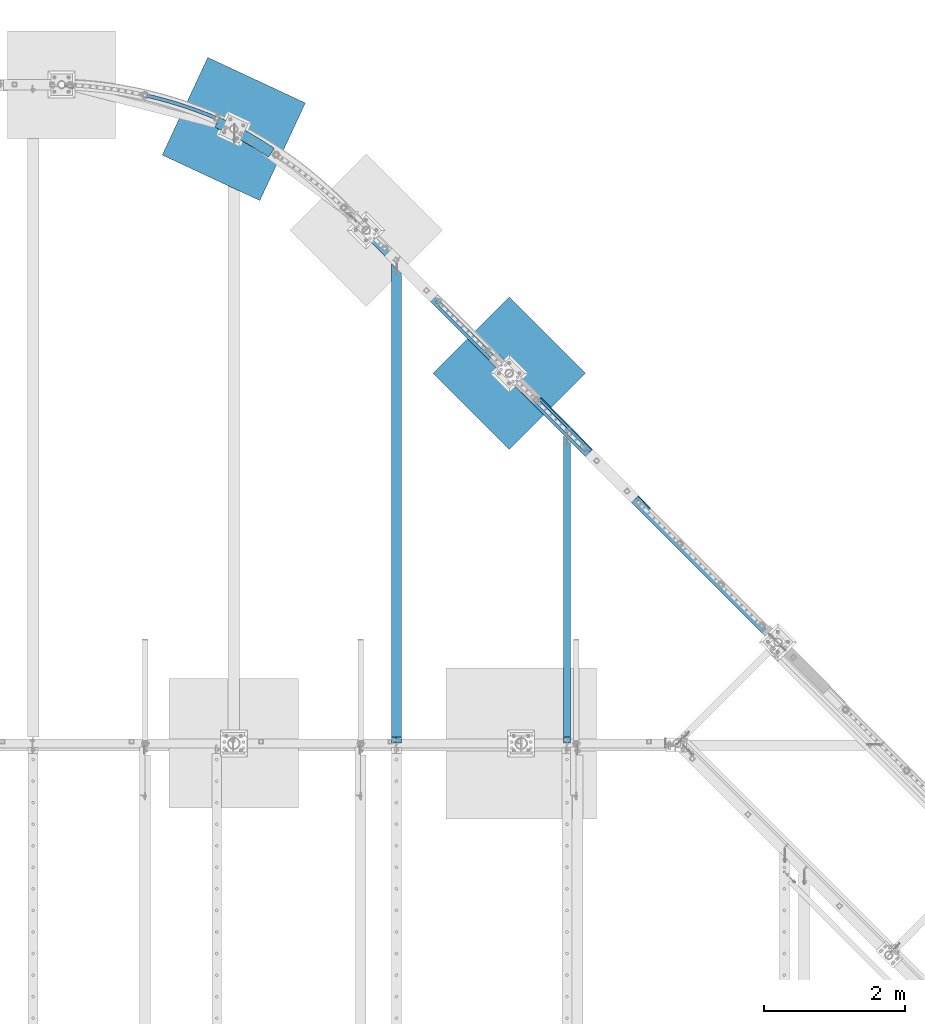
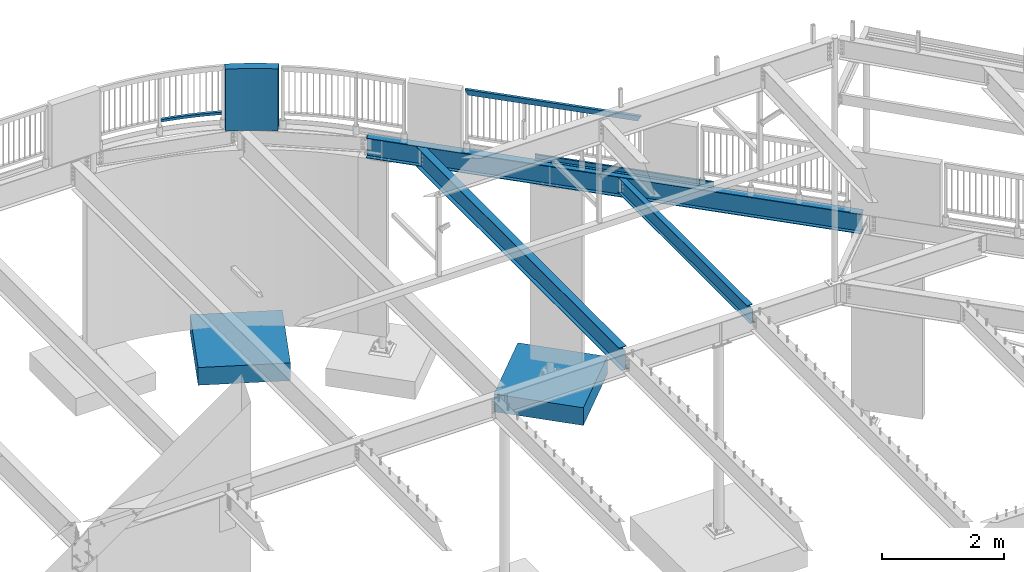
# One storey, part 331 of 975: 9 beams.
"""IFC2X3 building model written with IfcOpenShell, lengths in millimetres."""

from ifc_helpers import new_model, si_unit, frame, origin_with_axes, place, context, subcontext, project, spatial, faceted_brep, material, type_object, element, save


model = new_model("IFC2X3")

# Units and contexts
model_context = context("Model", 3, precision=1e-05, world=origin_with_axes())
body_context = subcontext(model_context, "Body", "Model", "MODEL_VIEW")
ifc_project = project(units=[si_unit("LENGTHUNIT", "METRE", prefix="MILLI"), si_unit("AREAUNIT", "SQUARE_METRE"), si_unit("VOLUMEUNIT", "CUBIC_METRE"), si_unit("MASSUNIT", "GRAM", prefix="KILO"), si_unit("TIMEUNIT", "SECOND"), si_unit("PLANEANGLEUNIT", "RADIAN"), si_unit("SOLIDANGLEUNIT", "STERADIAN"), si_unit("THERMODYNAMICTEMPERATUREUNIT", "DEGREE_CELSIUS"), si_unit("LUMINOUSINTENSITYUNIT", "LUMEN")], contexts=[model_context])

# Site, building, storey
site_placement = place(None, origin_with_axes())
site = spatial("IfcSite", under=ifc_project, at=site_placement, CompositionType="ELEMENT")
building_placement = place(site_placement, origin_with_axes())
building = spatial("IfcBuilding", under=site, at=building_placement, Name="Undefined", CompositionType="ELEMENT")
storey_placement = place(building_placement, origin_with_axes())
storey = spatial("IfcBuildingStorey", under=building, at=storey_placement, Name="Undefined", CompositionType="ELEMENT", Elevation=0.0)

# Beams
ifc_material_1 = material()
beam_type_1 = type_object("IfcBeamType", Name="HSS2X2X.188_TUBES", PredefinedType="NOTDEFINED")
beam_1_placement = place(storey_placement, frame((16519.5331439159, 29957.1361658595, 4229.10000192006), z_axis=(0.0, 0.0, 1.0), x_axis=(0.975010716016224, -0.222157835003697, 0.0)))
element("IfcBeam", 1, at=beam_1_placement, inside=storey, type_object=beam_type_1, material=ifc_material_1, Name="GUARDRAIL", ObjectType="HSS2X2X.188_TUBES", context=body_context, shape_type="Brep", body=[
    faceted_brep([(1150.31871985149, 124.980807145817, -25.3999999999996), (1150.31871985149, 124.980807145817, 25.3999999999996), (1187.76761016371, 124.51871128966, 25.3999999999996), (1187.76761016371, 124.51871128966, -25.3999999999996), (1225.21293697986, 123.82558949032, 25.3999999999996), (1225.21293697986, 123.82558949032, -25.3999999999996), (1262.6532750914, 122.90146812873, 25.3999999999996), (1262.6532750914, 122.90146812873, -25.3999999999996), (1300.08719947965, 121.746382377933, 25.3999999999996), (1300.08719947965, 121.746382377933, -25.3999999999996), (1337.51328537006, 120.360376201708, 25.3999999999996), (1337.51328537006, 120.360376201708, -25.3999999999996), (1374.93010828641, 118.743502352903, 25.3999999999996), (1374.93010828641, 118.743502352903, -25.3999999999996), (1412.33624410506, 116.895822371444, 25.3999999999996), (1412.33624410506, 116.895822371444, -25.3999999999996), (1449.73026910911, 114.817406581969, 25.3999999999996), (1449.73026910911, 114.817406581969, -25.3999999999996), (1487.11076004261, 112.508334091181, 25.3999999999996), (1487.11076004261, 112.508334091181, -25.3999999999996), (1524.47629416474, 109.968692784802, 25.3999999999996), (1524.47629416474, 109.968692784802, -25.3999999999996), (1561.82544930395, 107.198579324249, 25.3999999999996), (1561.82544930395, 107.198579324249, -25.3999999999996), (1599.15680391209, 104.198099142952, 25.3999999999996), (1599.15680391209, 104.198099142952, -25.3999999999996), (1636.46893711852, 100.967366442361, 25.3999999999996), (1636.46893711852, 100.967366442361, -25.3999999999996), (1673.76042878418, 97.5065041875496, 25.3999999999996), (1673.76042878418, 97.5065041875496, -25.3999999999996), (1711.02985955566, 93.8156441025785, 25.3999999999996), (1711.02985955566, 93.8156441025785, -25.3999999999996), (1748.2758109192, 89.8949266654745, 25.3999999999996), (1748.2758109192, 89.8949266654745, -25.3999999999996), (1785.4968652547, 85.744501102854, 25.3999999999996), (1785.4968652547, 85.744501102854, -25.3999999999996), (1822.69160588967, 81.3645253842988, 25.3999999999996), (1822.69160588967, 81.3645253842988, -25.3999999999996), (1859.85861715311, 76.7551662162805, 25.3999999999996), (1859.85861715311, 76.7551662162805, -25.3999999999996), (1896.99648442949, 71.9165990358742, 25.3999999999996), (1896.99648442949, 71.9165990358742, -25.3999999999996), (1934.10379421248, 66.8490080040283, 25.3999999999996), (1934.10379421248, 66.8490080040283, -25.3999999999996), (1971.17913415883, 61.5525859985864, 25.3999999999996), (1971.17913415883, 61.5525859985864, -25.3999999999996), (2008.22109314208, 56.0275346069466, 25.3999999999996), (2008.22109314208, 56.0275346069466, -25.3999999999996), (2045.2282613063, 50.2740641183846, 25.3999999999996), (2045.2282613063, 50.2740641183846, -25.3999999999996), (2082.19923011971, 44.2923935160434, 25.3999999999996), (2082.19923011971, 44.2923935160434, -25.3999999999996), (2119.13259242833, 38.0827504685949, 25.3999999999996), (2119.13259242833, 38.0827504685949, -25.3999999999996), (2132.13149665753, 35.8146830047481, 25.3999999999996), (2132.13149665753, 35.8146830047481, -25.3999999999996), (2110.55526379542, -11.9878939603732, 25.3999999999996), (2110.55526379542, -11.9878939603732, -25.3999999999996), (2123.09401412406, -14.1756731113128, -25.3999999999996), (2123.09401412406, -14.1756731113128, 25.3999999999996), (2073.93096728016, -5.83021445306804, 25.3999999999996), (2073.93096728016, -5.83021445306804, -25.3999999999996), (2037.26937895892, 0.101400328334421, 25.3999999999996), (2037.26937895892, 0.101400328334421, -25.3999999999996), (2000.57189421031, 5.80672462034272, 25.3999999999996), (2000.57189421031, 5.80672462034272, -25.3999999999996), (1963.83990977922, 11.2855412723002, 25.3999999999996), (1963.83990977922, 11.2855412723002, -25.3999999999996), (1927.07482372363, 16.5376417546795, 25.3999999999996), (1927.07482372363, 16.5376417546795, -25.3999999999996), (1890.27803536142, 21.5628261670136, 25.3999999999996), (1890.27803536142, 21.5628261670136, -25.3999999999996), (1853.45094521706, 26.3609032454988, 25.3999999999996), (1853.45094521706, 26.3609032454988, -25.3999999999996), (1816.59495496837, 30.9316903702711, 25.3999999999996), (1816.59495496837, 30.9316903702711, -25.3999999999996), (1779.71146739312, 35.2750135723545, 25.3999999999996), (1779.71146739312, 35.2750135723545, -25.3999999999996), (1742.80188631566, 39.390707540304, 25.3999999999996), (1742.80188631566, 39.390707540304, -25.3999999999996), (1705.86761655348, 43.2786156264701, 25.3999999999996), (1705.86761655348, 43.2786156264701, -25.3999999999996), (1668.91006386378, 46.9385898529872, 25.3999999999996), (1668.91006386378, 46.9385898529872, -25.3999999999996), (1631.93063488987, 50.370490917383, 25.3999999999996), (1631.93063488987, 50.370490917383, -25.3999999999996), (1594.93073710776, 53.5741881978829, 25.3999999999996), (1594.93073710776, 53.5741881978829, -25.3999999999996), (1557.91177877249, 56.5495597584159, 25.3999999999996), (1557.91177877249, 56.5495597584159, -25.3999999999996), (1520.87516886458, 59.2964923531908, 25.3999999999996), (1520.87516886458, 59.2964923531908, -25.3999999999996), (1483.82231703636, 61.8148814310625, 25.3999999999996), (1483.82231703636, 61.8148814310625, -25.3999999999996), (1446.75463355837, 64.1046311395039, 25.3999999999996), (1446.75463355837, 64.1046311395039, -25.3999999999996), (1409.67352926565, 66.1656543282297, 25.3999999999996), (1409.67352926565, 66.1656543282297, -25.3999999999996), (1372.58041550406, 67.9978725525216, 25.3999999999996), (1372.58041550406, 67.9978725525216, -25.3999999999996), (1335.47670407655, 69.601216076233, 25.3999999999996), (1335.47670407655, 69.601216076233, -25.3999999999996), (1298.3638071894, 70.9756238744158, 25.3999999999996), (1298.3638071894, 70.9756238744158, -25.3999999999996), (1261.24313739854, 72.1210436356632, 25.3999999999996), (1261.24313739854, 72.1210436356632, -25.3999999999996), (1224.11610755572, 73.0374317640963, 25.3999999999996), (1224.11610755572, 73.0374317640963, -25.3999999999996), (1186.98413075477, 73.7247533810223, 25.3999999999996), (1186.98413075477, 73.7247533810223, -25.3999999999996), (1149.84862027779, 74.1829823262451, 25.3999999999996), (1149.84862027779, 74.1829823262451, -25.3999999999996), (1114.28344501515, 74.4023999704295, 25.3999999999996), (1114.28344501515, 74.4023999704295, -25.3999999999996), (1114.13455093549, 125.204043641672, -25.3999999999996), (1114.13455093549, 125.204043641672, 25.3999999999996), (1150.27464801645, 120.218511068982, 20.6374999999998), (1150.27464801645, 120.218511068982, -20.6374999999998), (1187.69415896912, 119.756777735725, -20.6374999999998), (1187.69415896912, 119.756777735725, 20.6374999999998), (1225.11010922135, 119.064199703484, -20.6374999999998), (1225.11010922135, 119.064199703484, 20.6374999999998), (1262.52107468269, 118.140803332506, -20.6374999999998), (1262.52107468269, 118.140803332506, 20.6374999999998), (1299.92563145244, 116.986623768229, -20.6374999999998), (1299.92563145244, 116.986623768229, 20.6374999999998), (1337.32235587379, 115.601704939945, -20.6374999999998), (1337.32235587379, 115.601704939945, 20.6374999999998), (1374.70982458807, 113.986099559123, -20.6374999999998), (1374.70982458807, 113.986099559123, 20.6374999999998), (1412.08661458888, 112.139869117396, -20.6374999999998), (1412.08661458888, 112.139869117396, 20.6374999999998), (1449.45130327623, 110.063083884241, -20.6374999999998), (1449.45130327623, 110.063083884241, 20.6374999999998), (1486.80246851077, 107.755822904299, -20.6374999999998), (1486.80246851077, 107.755822904299, 20.6374999999998), (1524.13868866785, 105.218173994333, -20.6374999999998), (1524.13868866785, 105.218173994333, 20.6374999999998), (1561.45854269162, 102.450233739946, -20.6374999999998), (1561.45854269162, 102.450233739946, 20.6374999999998), (1598.76061014918, 99.4521074918521, -20.6374999999998), (1598.76061014918, 99.4521074918521, 20.6374999999998), (1636.04347128458, 96.2239093618919, -20.6374999999998), (1636.04347128458, 96.2239093618919, 20.6374999999998), (1673.30570707289, 92.7657622186816, -20.6374999999998), (1673.30570707289, 92.7657622186816, 20.6374999999998), (1710.54589927421, 89.0777976829486, -20.6374999999998), (1710.54589927421, 89.0777976829486, 20.6374999999998), (1747.76263048762, 85.1601561224888, -20.6374999999998), (1747.76263048762, 85.1601561224888, 20.6374999999998), (1784.95448420519, 81.0129866468706, -20.6374999999998), (1784.95448420519, 81.0129866468706, 20.6374999999998), (1822.12004486579, 76.6364471017368, -20.6374999999998), (1822.12004486579, 76.6364471017368, 20.6374999999998), (1859.25789790911, 72.030704062774, -20.6374999999998), (1859.25789790911, 72.030704062774, 20.6374999999998), (1896.36662982936, 67.1959328294179, -20.6374999999998), (1896.36662982936, 67.1959328294179, 20.6374999999998), (1933.44482822915, 62.1323174181452, -20.6374999999998), (1933.44482822915, 62.1323174181452, 20.6374999999998), (1970.49108187324, 56.8400505554964, -20.6374999999998), (1970.49108187324, 56.8400505554964, 20.6374999999998), (2007.50398074223, 51.3193336707045, -20.6374999999998), (2007.50398074223, 51.3193336707045, 20.6374999999998), (2044.48211608623, 45.5703768880703, -20.6374999999998), (2044.48211608623, 45.5703768880703, 20.6374999999998), (2081.4240804785, 39.5933990189369, -20.6374999999998), (2081.4240804785, 39.5933990189369, 20.6374999999998), (2118.32846786899, 33.3886275533732, -20.6374999999998), (2118.32846786899, 33.3886275533732, 20.6374999999998), (2131.28423267001, 31.1280871188719, -20.6374999999998), (2131.28423267001, 31.1280871188719, 20.6374999999998), (2123.94127811157, -9.48907722543663, -20.6374999999998), (2123.94127811157, -9.48907722543663, 20.6374999999998), (2111.35938835475, -7.29377104515879, -20.6374999999998), (2111.35938835475, -7.29377104515879, 20.6374999999998), (2074.70611692137, -1.13121995596157, -20.6374999999998), (2074.70611692137, -1.13121995596157, 20.6374999999998), (2038.01552417899, 4.80508755865594, -20.6374999999998), (2038.01552417899, 4.80508755865594, 20.6374999999998), (2001.28900661016, 10.5149255565848, -20.6374999999998), (2001.28900661016, 10.5149255565848, 20.6374999999998), (1964.52796206481, 15.9980767153829, -20.6374999999998), (1964.52796206481, 15.9980767153829, 20.6374999999998), (1927.73378970696, 21.2543323405553, -20.6374999999998), (1927.73378970696, 21.2543323405553, 20.6374999999998), (1890.90788996155, 26.2834923734699, -20.6374999999998), (1890.90788996155, 26.2834923734699, 20.6374999999998), (1854.05166446107, 31.0853653990125, -20.6374999999998), (1854.05166446107, 31.0853653990125, 20.6374999999998), (1817.16651599224, 35.659768652833, -20.6374999999998), (1817.16651599224, 35.659768652833, 20.6374999999998), (1780.25384844264, 40.0065280283379, -20.6374999999998), (1780.25384844264, 40.0065280283379, 20.6374999999998), (1743.31506674724, 44.1254780832824, -20.6374999999998), (1743.31506674724, 44.1254780832824, 20.6374999999998), (1706.35157683494, 48.0164620461001, -20.6374999999998), (1706.35157683494, 48.0164620461001, 20.6374999999998), (1669.36478557506, 51.6793318218552, -20.6374999999998), (1669.36478557506, 51.6793318218552, 20.6374999999998), (1632.35610072381, 55.1139479978519, -20.6374999999998), (1632.35610072381, 55.1139479978519, 20.6374999999998), (1595.32693087067, 58.3201798489899, -20.6374999999998), (1595.32693087067, 58.3201798489899, 20.6374999999998), (1558.27868538482, 61.2979053427116, -20.6374999999998), (1558.27868538482, 61.2979053427116, 20.6374999999998), (1521.21277436146, 64.0470111436516, -20.6374999999998), (1521.21277436146, 64.0470111436516, 20.6374999999998), (1484.13060856819, 66.5673926179516, -20.6374999999998), (1484.13060856819, 66.5673926179516, 20.6374999999998), (1447.03359939125, 68.8589538372398, -20.6374999999998), (1447.03359939125, 68.8589538372398, 20.6374999999998), (1409.92315878185, 70.9216075822842, -20.6374999999998), (1409.92315878185, 70.9216075822842, 20.6374999999998), (1372.80069920241, 72.7552753463096, -20.6374999999998), (1372.80069920241, 72.7552753463096, 20.6374999999998), (1335.66763357282, 74.359887337996, -20.6374999999998), (1335.66763357282, 74.359887337996, 20.6374999999998), (1298.52537521661, 75.7353824841193, -20.6374999999998), (1298.52537521661, 75.7353824841193, 20.6374999999998), (1261.37533780724, 76.8817084318871, -20.6374999999998), (1261.37533780724, 76.8817084318871, 20.6374999999998), (1224.21893531423, 77.7988215509322, -20.6374999999998), (1224.21893531423, 77.7988215509322, 20.6374999999998), (1187.05758194936, 78.4866869349571, -20.6374999999998), (1187.05758194936, 78.4866869349571, 20.6374999999998), (1149.89269211283, 78.9452784030873, -20.6374999999998), (1149.89269211283, 78.9452784030873, 20.6374999999998), (1114.26948619518, 79.1650540646078, 20.6374999999998), (1114.14850975546, 120.441389547494, 20.6374999999998), (1114.14850975546, 120.441389547494, -20.6374999999998), (1114.26948619518, 79.1650540646078, -20.6374999999998)], [[[0, 1, 2, 3]], [[3, 2, 4, 5]], [[5, 4, 6, 7]], [[7, 6, 8, 9]], [[9, 8, 10, 11]], [[11, 10, 12, 13]], [[13, 12, 14, 15]], [[15, 14, 16, 17]], [[17, 16, 18, 19]], [[19, 18, 20, 21]], [[21, 20, 22, 23]], [[23, 22, 24, 25]], [[25, 24, 26, 27]], [[27, 26, 28, 29]], [[29, 28, 30, 31]], [[31, 30, 32, 33]], [[33, 32, 34, 35]], [[35, 34, 36, 37]], [[37, 36, 38, 39]], [[39, 38, 40, 41]], [[41, 40, 42, 43]], [[43, 42, 44, 45]], [[45, 44, 46, 47]], [[47, 46, 48, 49]], [[49, 48, 50, 51]], [[51, 50, 52, 53]], [[53, 52, 54, 55]], [[56, 57, 58, 59]], [[60, 61, 57, 56]], [[62, 63, 61, 60]], [[64, 65, 63, 62]], [[66, 67, 65, 64]], [[68, 69, 67, 66]], [[70, 71, 69, 68]], [[72, 73, 71, 70]], [[74, 75, 73, 72]], [[76, 77, 75, 74]], [[78, 79, 77, 76]], [[80, 81, 79, 78]], [[82, 83, 81, 80]], [[84, 85, 83, 82]], [[86, 87, 85, 84]], [[88, 89, 87, 86]], [[90, 91, 89, 88]], [[92, 93, 91, 90]], [[94, 95, 93, 92]], [[96, 97, 95, 94]], [[98, 99, 97, 96]], [[100, 101, 99, 98]], [[102, 103, 101, 100]], [[104, 105, 103, 102]], [[106, 107, 105, 104]], [[108, 109, 107, 106]], [[110, 111, 109, 108]], [[111, 110, 112, 113]], [[0, 3, 5, 7, 9, 11, 13, 15, 17, 19, 21, 23, 25, 27, 29, 31, 33, 35, 37, 39, 41, 43, 45, 47, 49, 51, 53, 55, 58, 57, 61, 63, 65, 67, 69, 71, 73, 75, 77, 79, 81, 83, 85, 87, 89, 91, 93, 95, 97, 99, 101, 103, 105, 107, 109, 111, 113, 114]], [[1, 0, 114, 115]], [[110, 108, 106, 104, 102, 100, 98, 96, 94, 92, 90, 88, 86, 84, 82, 80, 78, 76, 74, 72, 70, 68, 66, 64, 62, 60, 56, 59, 54, 52, 50, 48, 46, 44, 42, 40, 38, 36, 34, 32, 30, 28, 26, 24, 22, 20, 18, 16, 14, 12, 10, 8, 6, 4, 2, 1, 115, 112]], [[116, 117, 118, 119]], [[119, 118, 120, 121]], [[121, 120, 122, 123]], [[123, 122, 124, 125]], [[125, 124, 126, 127]], [[127, 126, 128, 129]], [[129, 128, 130, 131]], [[131, 130, 132, 133]], [[133, 132, 134, 135]], [[135, 134, 136, 137]], [[137, 136, 138, 139]], [[139, 138, 140, 141]], [[141, 140, 142, 143]], [[143, 142, 144, 145]], [[145, 144, 146, 147]], [[147, 146, 148, 149]], [[149, 148, 150, 151]], [[151, 150, 152, 153]], [[153, 152, 154, 155]], [[155, 154, 156, 157]], [[157, 156, 158, 159]], [[159, 158, 160, 161]], [[161, 160, 162, 163]], [[163, 162, 164, 165]], [[165, 164, 166, 167]], [[167, 166, 168, 169]], [[169, 168, 170, 171]], [[58, 55, 54, 59], [172, 173, 171, 170]], [[174, 175, 173, 172]], [[176, 177, 175, 174]], [[178, 179, 177, 176]], [[180, 181, 179, 178]], [[182, 183, 181, 180]], [[184, 185, 183, 182]], [[186, 187, 185, 184]], [[188, 189, 187, 186]], [[190, 191, 189, 188]], [[192, 193, 191, 190]], [[194, 195, 193, 192]], [[196, 197, 195, 194]], [[198, 199, 197, 196]], [[200, 201, 199, 198]], [[202, 203, 201, 200]], [[204, 205, 203, 202]], [[206, 207, 205, 204]], [[208, 209, 207, 206]], [[210, 211, 209, 208]], [[212, 213, 211, 210]], [[214, 215, 213, 212]], [[216, 217, 215, 214]], [[218, 219, 217, 216]], [[220, 221, 219, 218]], [[222, 223, 221, 220]], [[224, 225, 223, 222]], [[226, 227, 225, 224]], [[116, 119, 121, 123, 125, 127, 129, 131, 133, 135, 137, 139, 141, 143, 145, 147, 149, 151, 153, 155, 157, 159, 161, 163, 165, 167, 169, 171, 173, 175, 177, 179, 181, 183, 185, 187, 189, 191, 193, 195, 197, 199, 201, 203, 205, 207, 209, 211, 213, 215, 217, 219, 221, 223, 225, 227, 228, 229]], [[117, 116, 229, 230]], [[226, 224, 222, 220, 218, 216, 214, 212, 210, 208, 206, 204, 202, 200, 198, 196, 194, 192, 190, 188, 186, 184, 182, 180, 178, 176, 174, 172, 170, 168, 166, 164, 162, 160, 158, 156, 154, 152, 150, 148, 146, 144, 142, 140, 138, 136, 134, 132, 130, 128, 126, 124, 122, 120, 118, 117, 230, 231]], [[227, 226, 231, 228]], [[114, 113, 112, 115], [230, 229, 228, 231]]]),
])
beam_type_2 = type_object("IfcBeamType", Name="HSS2X4X.188_TUBES", PredefinedType="NOTDEFINED")
beam_2_placement = place(storey_placement, frame((23828.6202255989, 24805.7275254122, 5130.8), z_axis=(0.0, 0.0, 1.0), x_axis=(-0.707064984951361, 0.707148574951355, 0.0)))
element("IfcBeam", 2, at=beam_2_placement, inside=storey, type_object=beam_type_2, material=ifc_material_1, Name="GUARDRAIL", ObjectType="HSS2X4X.188_TUBES", context=body_context, shape_type="Brep", body=[
    faceted_brep([(23.0201356913603, 20.6375000000066, -46.0375000000004), (23.0201356707403, -20.637499999998, -46.0375000000004), (2923.38430775475, -20.6374999982072, -46.0375000000004), (2923.38430775475, 20.6375000018088, -46.0375000000004), (-23.0201344869965, -20.6375000000062, 46.0375000000004), (2969.42452883534, -20.6374999981781, 46.0375000000004), (-23.0201344663728, 20.637499999998, 46.0375000000004), (2969.42452883534, 20.6375000018306, 46.0375000000004), (25.4015289777599, 25.4000000000078, -50.8000000000002), (-25.4015277480175, 25.3999999999983, 50.8000000000002), (2971.80591958088, 25.400000001835, 50.8000000000002), (2921.0029170092, 25.4000000018059, -50.8000000000002), (-25.4015277733961, -25.4000000000074, 50.8000000000002), (2971.80591958088, -25.3999999981752, 50.8000000000002), (25.4015289523813, -25.3999999999983, -50.8000000000002), (2921.00291700921, -25.3999999982043, -50.8000000000002)], [[[0, 1, 2, 3]], [[1, 4, 5, 2]], [[4, 6, 7, 5]], [[6, 0, 3, 7]], [[8, 9, 10, 11]], [[9, 12, 13, 10]], [[12, 14, 15, 13]], [[14, 8, 11, 15]], [[13, 15, 11, 10], [5, 7, 3, 2]], [[14, 12, 9, 8], [6, 4, 1, 0]]]),
])
ifc_material_2 = material(Name="STEEL/A36")
beam_type_3 = type_object("IfcBeamType", PredefinedType="NOTDEFINED")
beam_3_placement = place(storey_placement, frame((23646.6437294611, 25023.978551412, 3938.58749694824), z_axis=(0.704126271960334, -0.71007477996, 0.0), x_axis=(0.710074779960001, 0.704126271960333, 0.0)))
element("IfcBeam", 3, at=beam_3_placement, inside=storey, type_object=beam_type_3, material=ifc_material_2, Name="DECK_EDGE", context=body_context, shape_type="Brep", body=[
    faceted_brep([(1.03318598121405e-09, -1.58750000000009, -1524.00000000109), (-1.04046193882823e-09, -1.58750000000009, 1524.0000000011), (-1.04046193882823e-09, 1.58750000000009, 1524.0000000011), (1.03318598121405e-09, 1.58750000000009, -1524.00000000109), (47.6250001214066, 1.58750000000009, 1524.00000000113), (47.6250001235167, 1.58750000000009, -1524.00000000107), (50.8000001235196, -1.58750000000009, -1524.00000000106), (50.8000001214168, -1.58750000000009, 1524.00000000113), (47.6250001214503, 96.837499999901, 1524.00000000113), (47.625000123473, 96.8374999999951, -1524.00000000106), (50.8000001234759, 104.502628762961, -1524.00000000106), (50.8000001214605, 104.502628762867, 1524.00000000113), (38.6447461584321, 87.8572448731024, 1524.00000000113), (38.6447461604548, 87.8572448731024, -1524.00000000107), (36.3996819826862, 90.102308757891, 1524.00000000112), (36.3996819847016, 90.102308757891, -1524.00000000107)], [[[0, 1, 2, 3]], [[3, 2, 4, 5]], [[1, 0, 6, 7]], [[5, 4, 8, 9]], [[7, 6, 10, 11]], [[9, 8, 12, 13]], [[8, 4, 2, 1, 7, 11, 14, 12]], [[11, 10, 15, 14]], [[10, 6, 0, 3, 5, 9, 13, 15]], [[14, 15, 13, 12]]]),
])
ifc_material_3 = material(Name="CONCRETE/5000")
beam_type_4 = type_object("IfcBeamType", PredefinedType="NOTDEFINED")
beam_4_placement = place(storey_placement, frame((16542.2055721452, 29849.8508973598, 4559.3), z_axis=(0.0, 0.0, 1.0), x_axis=(1.0, 0.0, 0.0)))
element("IfcBeam", 4, at=beam_4_placement, inside=storey, type_object=beam_type_4, material=ifc_material_3, Name="LOW WALL", context=body_context, shape_type="Brep", body=[
    faceted_brep([(2119.37278195178, -521.502603851306, -622.3), (2288.54734114732, -604.544515984737, -622.3), (2288.54734114732, -604.544515984737, 622.3), (2119.37278195178, -521.502603851306, 622.3), (2454.29454999333, -694.232048058813, -622.3), (2454.29454999333, -694.232048058813, 622.3), (2616.35348119581, -790.424009611183, -622.3), (2616.35348119581, -790.424009611183, 622.3), (2774.46901372627, -892.968970591191, -622.3), (2774.46901372627, -892.968970591191, 622.3), (2803.8937170739, -913.755568601206, -622.3), (2803.8937170739, -913.755568601206, 622.3), (2891.80871883073, -789.306495938243, -622.3), (2891.80871883073, -789.306495938243, 622.3), (2859.91465899334, -766.775461626192, -622.3), (2859.91465899334, -766.775461626192, 622.3), (2696.72590082018, -660.940287994421, 622.3), (2696.72590082018, -660.940287994421, -622.3), (2529.46721781442, -561.661953344112, 622.3), (2529.46721781442, -561.661953344112, -622.3), (2358.40191670596, -469.096746444131, 622.3), (2358.40191670596, -469.096746444127, -622.3), (2183.79929678757, -383.39038793209, 622.3), (2183.79929678757, -383.39038793209, -622.3), (2111.30674211341, -351.30946000306, 622.3), (2049.64496940374, -490.645187678612, 622.3), (2049.64496940374, -490.645187678612, -622.3), (2111.30674211341, -351.30946000306, -622.3)], [[[0, 1, 2, 3]], [[1, 4, 5, 2]], [[4, 6, 7, 5]], [[6, 8, 9, 7]], [[9, 8, 10, 11]], [[10, 12, 13, 11]], [[14, 15, 13, 12]], [[16, 15, 14, 17]], [[18, 16, 17, 19]], [[20, 18, 19, 21]], [[22, 20, 21, 23]], [[3, 2, 5, 7, 9, 11, 13, 15, 16, 18, 20, 22, 24, 25]], [[0, 3, 25, 26]], [[23, 21, 19, 17, 14, 12, 10, 8, 6, 4, 1, 0, 26, 27]], [[22, 23, 27, 24]], [[26, 25, 24, 27]]]),
])
ifc_material_4 = material(Name="STEEL/A992")
beam_type_5 = type_object("IfcBeamType", Name="W16X31", PredefinedType="NOTDEFINED")
beam_5_placement = place(storey_placement, frame((20541.9585982056, 28092.6914017944, 3735.3875), z_axis=(0.0, 0.0, 1.0), x_axis=(0.707106781186513, -0.707106781186582, 3.1377567211166e-14)))
element("IfcBeam", 5, at=beam_5_placement, inside=storey, type_object=beam_type_5, material=ifc_material_4, Name="BEAM", ObjectType="W16X31", context=body_context, shape_type="Brep", body=[
    faceted_brep([(14.2870314626853, -69.8499999998385, 201.6125), (14.2870314626834, 69.8499999998312, 201.6125), (3.17496870513241, 69.8499999998312, 190.5), (3.17496870513605, 3.17499999998836, 190.5), (2.77798382233232, 3.17499999999563, 190.10299949646), (2.77798382233414, -3.17499999999563, 190.10299949646), (3.17496870513241, -3.17499999999563, 190.5), (3.17496870513241, -69.8499999998312, 190.5), (22.2250007627754, -3.17499999999563, 190.10299949646), (22.2250007627754, 3.17499999998836, 190.10299949646), (40.7122683045036, 3.17499999998836, 179.763105287907), (40.7122683045018, -3.17499999999563, 179.763105287907), (44.8249534616807, 3.17499999999563, 175.184922721185), (44.8249534616807, -3.17499999999563, 175.184922721185), (45.2798117859365, 3.17499999998836, 169.047574863894), (45.2798117859384, -3.17499999999563, 169.047574863894), (41.886960034215, 3.17499999998836, 163.91313314086), (41.8869600342168, -3.17499999999563, 163.91313314086), (36.0627638295646, 3.17499999998836, 161.925000000001), (36.0627638295646, -3.17499999999563, 161.925000000001), (6.34999999994761, 3.17499999998836, 161.925), (6.34999999994761, -3.17499999999563, 161.925), (8434.86465098199, 3.17499999998836, -190.5), (8434.86465098199, 69.8499999998239, -190.5), (6.34999999994761, 69.8499999998312, -190.5), (6.34999999994761, 3.17499999998836, -190.5), (8434.86465098199, 69.8499999998239, -201.6125), (8434.86465098199, -69.8499999998385, -201.6125), (6.34999999994943, -69.8499999998385, -201.6125), (6.34999999994761, 69.8499999998312, -201.6125), (8434.86465098199, -69.8499999998385, -190.5), (6.34999999994943, -69.8499999998385, -190.5), (8434.86465098199, -3.17499999999563, -190.5), (6.34999999994761, -3.17499999999563, -190.5), (8434.86465098199, 3.17499999998836, 190.5), (8434.86465098199, 69.8499999998239, 190.5), (8434.86465098199, 69.8499999998239, 201.6125), (8434.86465098199, -69.8499999998385, 201.6125), (8434.86465098199, -69.8499999998385, 190.5), (8434.86465098199, -3.17499999999563, 190.5)], [[[0, 1, 2, 3, 4, 5, 6, 7]], [[8, 9, 10, 11]], [[11, 10, 12, 13]], [[13, 12, 14, 15]], [[15, 14, 16, 17]], [[17, 16, 18, 19]], [[19, 18, 20, 21]], [[22, 23, 24, 25]], [[26, 27, 28, 29]], [[27, 30, 31, 28]], [[30, 32, 33, 31]], [[21, 20, 25, 24, 29, 28, 31, 33]], [[23, 26, 29, 24]], [[22, 34, 35, 36, 37, 38, 39, 32, 30, 27, 26, 23]], [[38, 37, 0, 7]], [[39, 38, 7, 6]], [[8, 11, 13, 15, 17, 19, 21, 33, 32, 39, 6, 5]], [[9, 8, 5, 4]], [[34, 22, 25, 20, 18, 16, 14, 12, 10, 9, 4, 3]], [[35, 34, 3, 2]], [[36, 35, 2, 1]], [[37, 36, 1, 0]]]),
])
beam_type_6 = type_object("IfcBeamType", Name="W16X26", PredefinedType="NOTDEFINED")
beam_6_placement = place(storey_placement, frame((21158.2, 20621.7350997173, 3736.975), z_axis=(0.0, 0.0, 1.0), x_axis=(0.0, 1.0, 0.0)))
element("IfcBeam", 6, at=beam_6_placement, inside=storey, type_object=beam_type_6, material=ifc_material_4, Name="BEAM", ObjectType="W16X26", context=body_context, shape_type="Brep", body=[
    faceted_brep([(29.368749999996, -3.17499999999927, -190.5), (29.368749999996, -69.8499999999985, -190.5), (6668.1215707093, -69.8499999999985, -190.5), (6734.79657070931, -3.17499999999927, -190.5), (29.368749999996, -69.8499999999985, -200.025), (6668.1215707093, -69.8499999999985, -200.025), (29.368749999996, 69.8499999999985, -200.025), (6807.82157070931, 69.8499999999985, -200.025), (29.368749999996, 69.8499999999985, -190.5), (6807.82157070931, 69.8499999999985, -190.5), (6741.1465707093, 3.17499999999927, -190.5), (6741.1465707093, 3.17499999999927, 190.5), (6807.82157070931, 69.8499999999985, 190.5), (6807.82157070931, 69.8499999999985, 200.025), (6668.1215707093, -69.8499999999985, 200.025), (6668.1215707093, -69.8499999999985, 190.5), (6734.79657070931, -3.17499999999927, 190.5), (29.368749999996, 3.17499999999927, -190.5), (110.428829708775, -3.17499999999927, 175.591729922588), (110.428829708775, 3.17499999999927, 175.591729922588), (105.568750190729, 3.17499999999927, 174.625), (105.568750190729, -3.17499999999927, 174.625), (114.549006176929, -3.17499999999927, 178.344743823066), (114.549006176929, 3.17499999999927, 178.344743823066), (117.302020077406, -3.17499999999927, 182.46492029122), (117.302020077406, 3.17499999999927, 182.46492029122), (118.268749999994, -3.17499999999927, 187.324999809266), (118.268749999994, 3.17499999999927, 187.324999809266), (29.368749999996, 3.17499999999927, 174.625), (118.268749999994, 3.17499999999927, 190.5), (118.268749999994, 69.8499999999985, 190.5), (118.268749999994, 69.8499999999985, 200.025), (118.268749999994, -69.8499999999985, 200.024999810586), (118.268749999994, -69.8499999999985, 190.5), (118.268749999994, -3.17499999999927, 190.5), (29.368749999996, -3.17499999999927, 174.625)], [[[0, 1, 2, 3]], [[1, 4, 5, 2]], [[4, 6, 7, 5]], [[6, 8, 9, 7]], [[10, 11, 12, 13, 14, 15, 16, 3, 2, 5, 7, 9]], [[8, 17, 10, 9]], [[18, 19, 20, 21]], [[22, 23, 19, 18]], [[24, 25, 23, 22]], [[26, 27, 25, 24]], [[11, 10, 17, 28, 20, 19, 23, 25, 27, 29]], [[12, 11, 29, 30]], [[13, 12, 30, 31]], [[14, 13, 31, 32]], [[15, 14, 32, 33]], [[16, 15, 33, 34]], [[32, 31, 30, 29, 27, 26, 34, 33]], [[24, 22, 18, 21, 35, 0, 3, 16, 34, 26]], [[17, 8, 6, 4, 1, 0, 35, 28]], [[21, 20, 28, 35]]]),
])
beam_type_7 = type_object("IfcBeamType", Name="W12X19", PredefinedType="NOTDEFINED")
beam_7_placement = place(storey_placement, frame((23571.2, 20621.7350997173, 3783.0125), z_axis=(0.0, 0.0, 1.0), x_axis=(0.0, 1.0, 0.0)))
element("IfcBeam", 7, at=beam_7_placement, inside=storey, type_object=beam_type_7, material=ifc_material_4, Name="BEAM", ObjectType="W12X19", context=body_context, shape_type="Brep", body=[
    faceted_brep([(105.568750190741, -3.17499999999927, 128.5875), (105.568750190741, 3.17499999999927, 128.5875), (29.3687500000015, 3.17499999999927, 128.5875), (29.3687500000015, -3.17499999999927, 128.5875), (110.428829708788, -3.17499999999927, 129.554229922588), (110.428829708788, 3.17499999999927, 129.554229922588), (114.549006176941, -3.17499999999927, 132.307243823066), (114.549006176941, 3.17499999999927, 132.307243823066), (117.302020077419, -3.17499999999927, 136.42742029122), (117.302020077419, 3.17499999999927, 136.42742029122), (118.268750000007, -3.17499999999927, 141.287499809265), (118.268750000007, 3.17499999999927, 141.287499809265), (118.268750000007, -50.7999999999993, 153.987499810998), (118.268750000007, 50.7999999999993, 153.9875), (118.268750000007, 50.8000000000002, 144.4625), (118.268750000007, 3.17500000000018, 144.4625), (118.268750000007, -3.17500000000018, 144.4625), (118.268750000007, -50.8000000000002, 144.4625), (29.3687500000015, -3.17499999999927, -144.4625), (29.3687500000015, -50.7999999999993, -144.4625), (4274.17157070931, -50.7999999999993, -144.4625), (4321.79657070931, -3.17499999999927, -144.4625), (29.3687500000015, -50.7999999999993, -153.9875), (4274.17157070931, -50.7999999999993, -153.9875), (29.3687500000015, 50.7999999999993, -153.9875), (4375.7715707093, 50.7999999999993, -153.9875), (29.3687500000015, 50.7999999999993, -144.4625), (29.3687500000015, 3.17499999999927, -144.4625), (4328.1465707093, 3.17499999999927, -144.4625), (4375.7715707093, 50.7999999999993, -144.4625), (4328.1465707093, 3.17499999999927, 144.4625), (4375.7715707093, 50.7999999999993, 144.4625), (4375.7715707093, 50.7999999999993, 153.9875), (4274.17157070931, -50.7999999999993, 153.9875), (4274.17157070931, -50.7999999999993, 144.4625), (4321.79657070931, -3.17499999999927, 144.4625)], [[[0, 1, 2, 3]], [[4, 5, 1, 0]], [[6, 7, 5, 4]], [[8, 9, 7, 6]], [[10, 11, 9, 8]], [[12, 13, 14, 15, 11, 10, 16, 17]], [[18, 19, 20, 21]], [[19, 22, 23, 20]], [[22, 24, 25, 23]], [[26, 27, 28, 29]], [[24, 26, 29, 25]], [[28, 30, 31, 32, 33, 34, 35, 21, 20, 23, 25, 29]], [[34, 33, 12, 17]], [[35, 34, 17, 16]], [[8, 6, 4, 0, 3, 18, 21, 35, 16, 10]], [[27, 26, 24, 22, 19, 18, 3, 2]], [[30, 28, 27, 2, 1, 5, 7, 9, 11, 15]], [[31, 30, 15, 14]], [[32, 31, 14, 13]], [[33, 32, 13, 12]]]),
])
beam_type_8 = type_object("IfcBeamType", PredefinedType="NOTDEFINED")
for number, where, z_axis, x_axis, name in (
    (8, (18537.4648843821, 28644.8059663621, -482.6), (0.0, 0.0, -1.0), (0.422618261967726, 0.906307786930786, 0.0), "FOOTING"),
    (9, (22216.4096327311, 25340.6096327255, -482.6), (0.0, 0.0, -1.0), (0.707106781186548, 0.707106781186548, 0.0), "FOOTING"),
):
    element("IfcBeam", number, at=place(storey_placement, frame(where, z_axis=z_axis, x_axis=x_axis)), inside=storey, type_object=beam_type_8, material=ifc_material_3, Name=name, context=body_context, shape_type="Brep", body=[
        faceted_brep([(4.8748916015029e-10, 762.000000001049, -177.8), (4.8748916015029e-10, 762.000000001049, 177.8), (1524.00000000259, 762.000000000074, 177.8), (1524.00000000259, 762.000000000074, -177.8), (-4.80213202536106e-10, -762.000000001047, 177.8), (1524.00000000162, -762.00000000202, 177.8), (-4.80213202536106e-10, -762.000000001047, -177.8), (1524.00000000162, -762.00000000202, -177.8)], [[[0, 1, 2, 3]], [[1, 4, 5, 2]], [[4, 6, 7, 5]], [[6, 0, 3, 7]], [[5, 7, 3, 2]], [[6, 4, 1, 0]]]),
    ])

save(model, "model.ifc")
